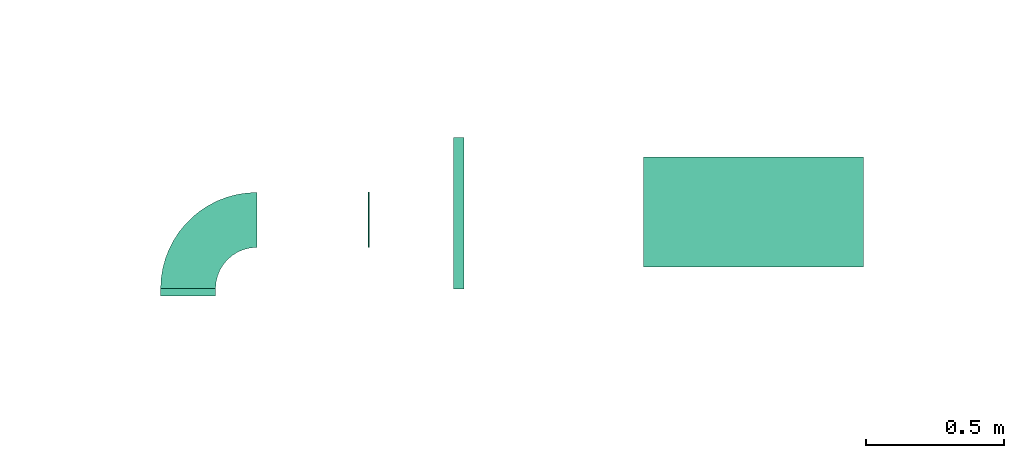
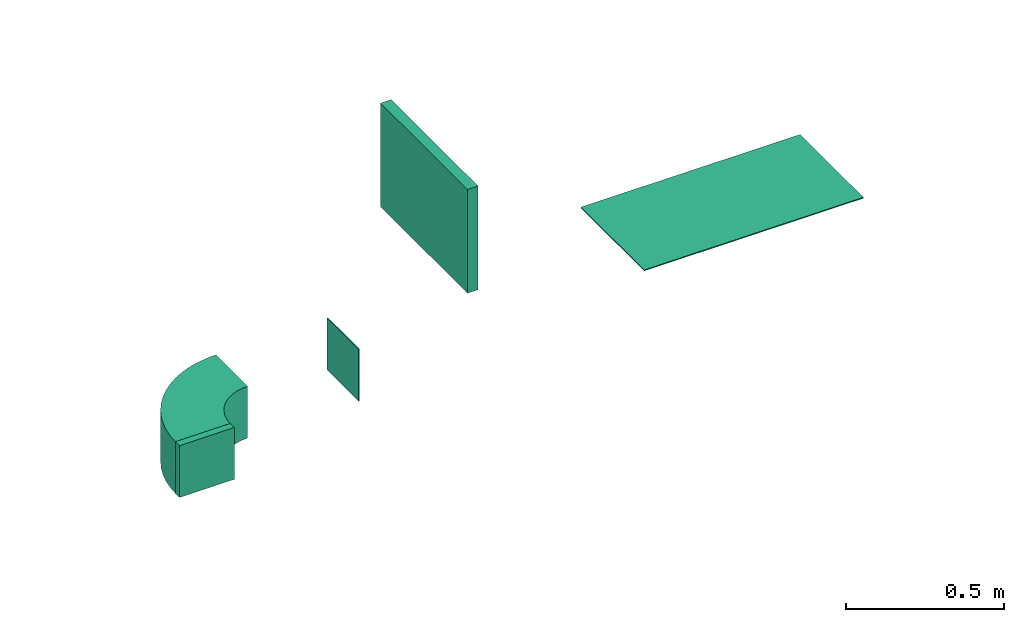
# One storey, part 3 of 7: 2 flow fittings, 2 flow terminals, 1 flow segment.
"""IFC2X3 building model written with IfcOpenShell, lengths in millimetres."""

from ifc_helpers import new_model, entity, si_unit, converted_unit, derived_unit, direction, frame, frame_2d, origin, origin_2d_with_axis, place, context, subcontext, project, spatial, polyline, circle_curve, parameter, trimmed, segment, composite_curve, rectangle, outline, extrude, source, transform, mapped, material, type_object, type_shapes, element, save


model = new_model("IFC2X3")

# Units and contexts
model_context = context("Model", 3, precision=0.01, world=origin(), true_north=direction((6.12303176911189e-17, 1.0)))
body_context = subcontext(model_context, "Body", "Model", "MODEL_VIEW")
ifc_project = project(units=[si_unit("LENGTHUNIT", "METRE", prefix="MILLI"), si_unit("AREAUNIT", "SQUARE_METRE"), si_unit("VOLUMEUNIT", "CUBIC_METRE"), converted_unit("PLANEANGLEUNIT", "DEGREE", entity("IfcRatioMeasure", 0.0174532925199433), si_unit("PLANEANGLEUNIT", "RADIAN"), dimensions=[0, 0, 0, 0, 0, 0, 0]), si_unit("MASSUNIT", "GRAM", prefix="KILO"), derived_unit("MASSDENSITYUNIT", [(si_unit("MASSUNIT", "GRAM", prefix="KILO"), 1), (si_unit("LENGTHUNIT", "METRE"), -3)]), derived_unit("MOMENTOFINERTIAUNIT", [(si_unit("LENGTHUNIT", "METRE"), 4)]), si_unit("TIMEUNIT", "SECOND"), si_unit("FREQUENCYUNIT", "HERTZ"), si_unit("THERMODYNAMICTEMPERATUREUNIT", "DEGREE_CELSIUS"), derived_unit("THERMALTRANSMITTANCEUNIT", [(si_unit("MASSUNIT", "GRAM", prefix="KILO"), 1), (si_unit("THERMODYNAMICTEMPERATUREUNIT", "KELVIN"), -1), (si_unit("TIMEUNIT", "SECOND"), -3)]), derived_unit("VOLUMETRICFLOWRATEUNIT", [(si_unit("LENGTHUNIT", "METRE"), 3), (si_unit("TIMEUNIT", "SECOND"), -1)]), derived_unit("MASSFLOWRATEUNIT", [(si_unit("MASSUNIT", "GRAM", prefix="KILO"), 1), (si_unit("TIMEUNIT", "SECOND"), -1)]), derived_unit("ROTATIONALFREQUENCYUNIT", [(si_unit("TIMEUNIT", "SECOND"), -1)]), si_unit("ELECTRICCURRENTUNIT", "AMPERE"), si_unit("ELECTRICVOLTAGEUNIT", "VOLT"), si_unit("POWERUNIT", "WATT"), si_unit("FORCEUNIT", "NEWTON", prefix="KILO"), si_unit("ILLUMINANCEUNIT", "LUX"), si_unit("LUMINOUSFLUXUNIT", "LUMEN"), si_unit("LUMINOUSINTENSITYUNIT", "CANDELA"), derived_unit("USERDEFINED", [(si_unit("MASSUNIT", "GRAM", prefix="KILO"), -1), (si_unit("LENGTHUNIT", "METRE"), -2), (si_unit("TIMEUNIT", "SECOND"), 3), (si_unit("LUMINOUSFLUXUNIT", "LUMEN"), 1)]), derived_unit("LINEARVELOCITYUNIT", [(si_unit("LENGTHUNIT", "METRE"), 1), (si_unit("TIMEUNIT", "SECOND"), -1)]), si_unit("PRESSUREUNIT", "PASCAL"), derived_unit("USERDEFINED", [(si_unit("LENGTHUNIT", "METRE"), -2), (si_unit("MASSUNIT", "GRAM", prefix="KILO"), 1), (si_unit("TIMEUNIT", "SECOND"), -2)]), derived_unit("LINEARFORCEUNIT", [(si_unit("MASSUNIT", "GRAM", prefix="KILO"), 1), (si_unit("LENGTHUNIT", "METRE"), 1), (si_unit("TIMEUNIT", "SECOND"), -2), (si_unit("LENGTHUNIT", "METRE"), -1)]), derived_unit("PLANARFORCEUNIT", [(si_unit("MASSUNIT", "GRAM", prefix="KILO"), 1), (si_unit("LENGTHUNIT", "METRE"), 1), (si_unit("TIMEUNIT", "SECOND"), -2), (si_unit("LENGTHUNIT", "METRE"), -2)])], contexts=[model_context])

# Site, building, storey
site_placement = place(None, origin())
site = spatial("IfcSite", under=ifc_project, at=site_placement, CompositionType="ELEMENT")
building_placement = place(site_placement, origin())
building = spatial("IfcBuilding", under=site, at=building_placement, CompositionType="ELEMENT")
storey_placement = place(building_placement, frame((0.0, 0.0, 15900.0)))
storey = spatial("IfcBuildingStorey", under=building, at=storey_placement, CompositionType="ELEMENT", Elevation=15900.0)

# Flow segment
duct_segment_type = type_object("IfcDuctSegmentType", PredefinedType="NOTDEFINED")
flow_segment_placement = place(storey_placement, frame((11209.73, 14469.56, 3000.0)))
element("IfcFlowSegment", 1, at=flow_segment_placement, inside=storey, type_object=duct_segment_type, context=body_context, shape_type="SweptSolid", body=[
    extrude(rectangle(XDim=38.7531418678463, YDim=550.000000000001, at=origin_2d_with_axis()), frame((19.38, 275.0, 0.0)), (0.0, 0.0, 1.0), 400.0),
])

# Flow terminals
ifc_material_1 = material()
air_terminal_type_1 = type_object("IfcAirTerminalType", PredefinedType="NOTDEFINED", material=ifc_material_1)
shared_shape_1 = source(origin(), body_context, "Body", "SweptSolid", [
    extrude(rectangle(XDim=4.0, YDim=799.999999999999, at=origin_2d_with_axis()), frame((0.0, -2.0, -200.0), z_axis=(0.0, 0.0, 1.0), x_axis=(0.0, 1.0, 0.0)), (0.0, 0.0, 1.0), 400.000000000005),
])
type_shapes(air_terminal_type_1, [shared_shape_1])
flow_terminal_1_placement = place(storey_placement, frame((12300.13, 14749.08, 2800.0), z_axis=(0.0, 1.0, 0.0), x_axis=(-1.0, 0.0, 0.0)))
element("IfcFlowTerminal", 2, at=flow_terminal_1_placement, inside=storey, type_object=air_terminal_type_1, material=ifc_material_1, context=body_context, shape_type="MappedRepresentation", body=[
    mapped(shared_shape_1, transform((0.0, 0.0, 0.0), scale=1.0)),
])
air_terminal_type_2 = type_object("IfcAirTerminalType", PredefinedType="NOTDEFINED", material=ifc_material_1)
shared_shape_2 = source(origin(), body_context, "Body", "SweptSolid", [
    extrude(rectangle(XDim=4.0, YDim=199.999999999999, at=origin_2d_with_axis()), frame((0.0, -2.0, -100.0), z_axis=(0.0, 0.0, 1.0), x_axis=(0.0, 1.0, 0.0)), (0.0, 0.0, 1.0), 200.000000000005),
])
type_shapes(air_terminal_type_2, [shared_shape_2])
flow_terminal_2_placement = place(storey_placement, frame((10899.87, 14720.82, 2700.0), z_axis=(0.0, 0.0, 1.0), x_axis=(0.0, 1.0, 0.0)))
element("IfcFlowTerminal", 3, at=flow_terminal_2_placement, inside=storey, type_object=air_terminal_type_2, material=ifc_material_1, context=body_context, shape_type="MappedRepresentation", body=[
    mapped(shared_shape_2, transform((0.0, 0.0, 0.0), scale=1.0)),
])

# Flow fittings
ifc_material_2 = material()
duct_fitting_type_1 = type_object("IfcDuctFittingType", PredefinedType="NOTDEFINED", material=ifc_material_2)
shared_shape_3 = source(origin(), body_context, "Body", "SweptSolid", [
    extrude(rectangle(XDim=200.0, YDim=26.096, at=origin_2d_with_axis()), frame((6.95, 0.0, -100.0), z_axis=(0.0, 0.0, 1.0), x_axis=(0.0, -1.0, 0.0)), (0.0, 0.0, 1.0), 200.0),
])
type_shapes(duct_fitting_type_1, [shared_shape_3])
flow_fitting_1_placement = place(storey_placement, frame((10244.72, 14450.84, 2700.0), z_axis=(1.0, 0.0, 0.0), x_axis=(0.0, 1.0, 0.0)))
element("IfcFlowFitting", 4, at=flow_fitting_1_placement, inside=storey, type_object=duct_fitting_type_1, material=ifc_material_2, context=body_context, shape_type="MappedRepresentation", body=[
    mapped(shared_shape_3, transform((0.0, 0.0, 0.0), scale=1.0)),
])
duct_fitting_type_2 = type_object("IfcDuctFittingType", PredefinedType="NOTDEFINED", material=ifc_material_2)
shared_shape_4 = source(origin(), body_context, "Body", "SweptSolid", [
    extrude(outline(composite_curve([segment(polyline([(-225.0, -125.0), (-25.0, -125.0)]), True, "CONTINUOUS"), segment(trimmed(circle_curve(frame_2d((125.0, -125.0), x_axis=(0.0, 1.0)), 150.0), [parameter(0.0)], [parameter(90.0000000000001)], True, "PARAMETER"), False, "CONTINUOUS"), segment(polyline([(125.0, 25.0), (125.0, 225.0)]), True, "CONTINUOUS"), segment(trimmed(circle_curve(frame_2d((125.0, -125.0), x_axis=(0.0, 1.0)), 350.0), [parameter(0.0)], [parameter(90.0000000000001)], True, "PARAMETER"), True, "CONTINUOUS")], self_intersect=False)), frame((-125.0, 125.0, -100.0), z_axis=(0.0, 0.0, 1.0), x_axis=(-1.0, 0.0, 0.0)), (0.0, 0.0, 1.0), 200.0),
])
type_shapes(duct_fitting_type_2, [shared_shape_4])
flow_fitting_2_placement = place(storey_placement, frame((10244.72, 14720.84, 2700.0), z_axis=(0.0, 0.0, 1.0), x_axis=(-1.0, 0.0, 0.0)))
element("IfcFlowFitting", 5, at=flow_fitting_2_placement, inside=storey, type_object=duct_fitting_type_2, material=ifc_material_2, context=body_context, shape_type="MappedRepresentation", body=[
    mapped(shared_shape_4, transform((0.0, 0.0, 0.0), scale=1.0)),
])

save(model, "model.ifc")
